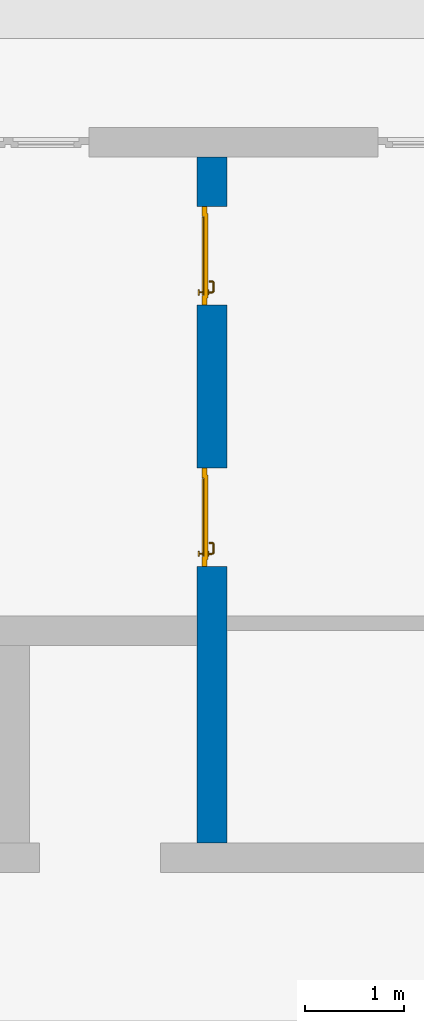
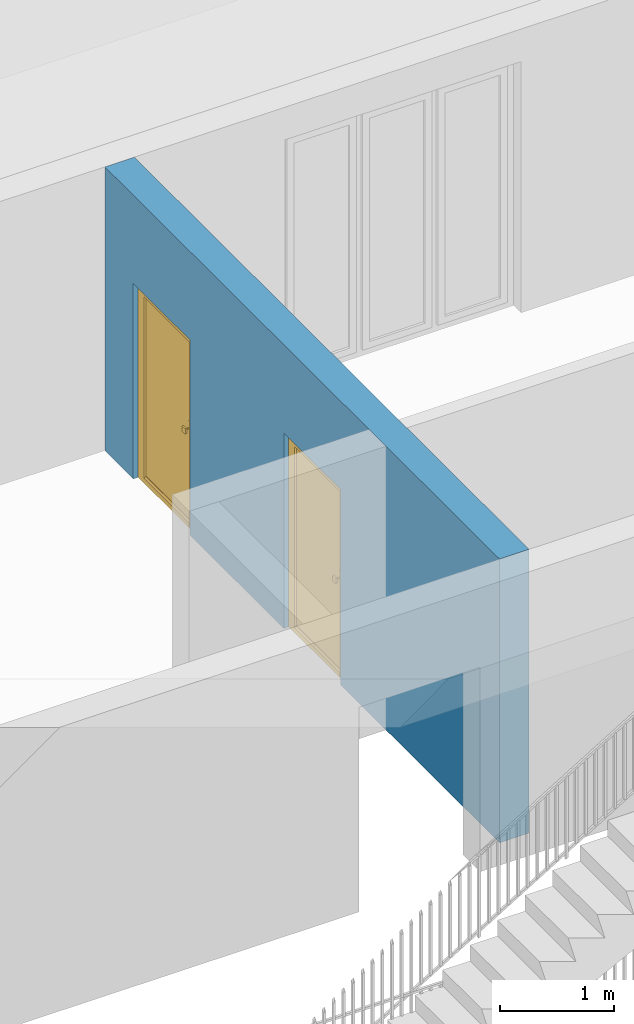
# One storey, part 11 of 23: 2 doors, 1 wall, 2 openings.
"""IFC4 building model written with IfcOpenShell, lengths in metres."""

from ifc_helpers import new_model, entity, si_unit, converted_unit, derived_unit, direction, frame, origin_with_axes, place, context, subcontext, project, spatial, polygons, source, transform, mapped, material, type_object, element, fill, save


model = new_model("IFC4")

# Units and contexts
model_context = context("Model", 3, precision=1e-05, world=origin_with_axes(), true_north=direction((0.0, 1.0)))
body_context = subcontext(model_context, "Body", "Model", "MODEL_VIEW")
ifc_project = project(units=[si_unit("LENGTHUNIT", "METRE"), si_unit("AREAUNIT", "SQUARE_METRE"), si_unit("VOLUMEUNIT", "CUBIC_METRE"), converted_unit("PLANEANGLEUNIT", "DEGREE", entity("IfcPlaneAngleMeasure", 0.0174532925199), si_unit("PLANEANGLEUNIT", "RADIAN"), dimensions=[0, 0, 0, 0, 0, 0, 0]), converted_unit("TIMEUNIT", "Year", entity("IfcTimeMeasure", 31556926.0), si_unit("TIMEUNIT", "SECOND"), dimensions=[0, 0, 1, 0, 0, 0, 0]), si_unit("MASSUNIT", "GRAM", prefix="KILO"), si_unit("THERMODYNAMICTEMPERATUREUNIT", "DEGREE_CELSIUS"), si_unit("LUMINOUSINTENSITYUNIT", "LUMEN"), si_unit("ENERGYUNIT", "JOULE", prefix="MEGA"), derived_unit("THERMALCONDUCTANCEUNIT", [(si_unit("POWERUNIT", "WATT"), 1), (si_unit("LENGTHUNIT", "METRE"), -1), (si_unit("THERMODYNAMICTEMPERATUREUNIT", "KELVIN"), -1)]), derived_unit("SPECIFICHEATCAPACITYUNIT", [(si_unit("ENERGYUNIT", "JOULE"), 1), (si_unit("MASSUNIT", "GRAM", prefix="KILO"), -1), (si_unit("THERMODYNAMICTEMPERATUREUNIT", "KELVIN"), -1)]), derived_unit("MASSDENSITYUNIT", [(si_unit("MASSUNIT", "GRAM", prefix="KILO"), 1), (si_unit("VOLUMEUNIT", "CUBIC_METRE"), -1)])], contexts=[model_context])

# Site, building, storey
site_placement = place(None, origin_with_axes())
site = spatial("IfcSite", under=ifc_project, at=site_placement, CompositionType="ELEMENT")
building_placement = place(site_placement, origin_with_axes())
building = spatial("IfcBuilding", under=site, at=building_placement, CompositionType="ELEMENT")
storey_placement = place(building_placement, origin_with_axes())
storey = spatial("IfcBuildingStorey", under=building, at=storey_placement, Name="0. Geschoss", CompositionType="ELEMENT", Elevation=0.0)

# Wall, openings, doors
ifc_material = material()
wall_type = type_object("IfcWallType", Name="300", PredefinedType="NOTDEFINED")
wall_placement = place(storey_placement, frame((-0.742199380397, 1.37118776896, 0.0), z_axis=(0.0, 0.0, 1.0), x_axis=(0.0, 1.0, 0.0)))
wall = element("IfcWall", 1, at=wall_placement, inside=storey, type_object=wall_type, material=ifc_material, Name="Wand-001", PredefinedType="NOTDEFINED", context=body_context, shape_type="Tessellation", body=[
    polygons([(3.1, -0.3, 0.0), (3.1, -0.3, 2.1), (4.1, -0.3, 2.1), (4.1, -0.3, 0.0), (5.75, -0.3, 0.0), (5.75, -0.3, 2.1), (6.75, -0.3, 2.1), (6.75, -0.3, 0.0), (7.25, -0.3, 0.0), (7.25, -0.3, 3.05), (0.3, -0.3, 3.05), (0.3, -0.3, 0.0), (3.1, -0.05, 0.0), (3.1, 0.0, 0.0), (3.1, 0.0, 2.1), (4.1, 0.0, 2.1), (4.1, -0.05, 0.0), (4.1, 0.0, 0.0), (5.75, 0.0, 0.0), (5.75, 0.0, 2.1), (6.75, 0.0, 2.1), (6.75, 0.0, 0.0), (7.25, 0.0, 0.0), (7.25, 0.0, 3.05), (0.3, 0.0, 3.05), (0.3, 0.0, 0.0)], [[[1, 2, 3, 4, 5, 6, 7, 8, 9, 10, 11, 12]], [[2, 1, 13, 14, 15]], [[3, 2, 15, 16]], [[17, 4, 3, 16, 18]], [[4, 17, 18, 19, 5]], [[19, 20, 6, 5]], [[20, 21, 7, 6]], [[21, 22, 8, 7]], [[23, 9, 8, 22]], [[23, 24, 10, 9]], [[25, 11, 10, 24]], [[12, 11, 25, 26]], [[13, 1, 12, 26, 14]], [[19, 18, 16, 15, 14, 26, 25, 24, 23, 22, 21, 20]]], closed=True),
])
opening_1_placement = place(wall_placement, frame((6.25, 0.0, 0.0), z_axis=(0.0, 0.0, 1.0), x_axis=(1.0, 0.0, 0.0)))
opening_1 = element("IfcOpeningElement", 2, at=opening_1_placement, cuts=wall, context=body_context, identifier="Reference", shape_type="Tessellation", body=[
    polygons([(-0.5, -0.05, 0.0), (-0.5, -0.05, 2.1), (-0.5, 0.001, 2.1), (-0.5, 0.001, 0.0), (-0.5, -0.301, 0.0), (-0.5, -0.301, 2.1), (0.5, -0.05, 2.1), (0.5, 0.001, 2.1), (0.5, -0.301, 2.1), (0.5, 0.001, 0.0), (0.5, -0.05, 0.0), (0.5, -0.301, 0.0)], [[[1, 2, 3, 4]], [[2, 1, 5, 6]], [[7, 8, 3, 2, 6, 9]], [[8, 10, 4, 3]], [[1, 4, 10, 11, 12, 5]], [[6, 5, 12, 9]], [[7, 11, 10, 8]], [[11, 7, 9, 12]]], closed=True),
])
opening_2_placement = place(wall_placement, frame((3.6, 0.0, 0.0), z_axis=(0.0, 0.0, 1.0), x_axis=(1.0, 0.0, 0.0)))
opening_2 = element("IfcOpeningElement", 3, at=opening_2_placement, cuts=wall, context=body_context, identifier="Reference", shape_type="Tessellation", body=[
    polygons([(-0.5, -0.05, 0.0), (-0.5, -0.05, 2.1), (-0.5, 0.001, 2.1), (-0.5, 0.001, 0.0), (-0.5, -0.301, 0.0), (-0.5, -0.301, 2.1), (0.5, -0.05, 2.1), (0.5, 0.001, 2.1), (0.5, -0.301, 2.1), (0.5, 0.001, 0.0), (0.5, -0.05, 0.0), (0.5, -0.301, 0.0)], [[[1, 2, 3, 4]], [[2, 1, 5, 6]], [[7, 8, 3, 2, 6, 9]], [[8, 10, 4, 3]], [[1, 4, 10, 11, 12, 5]], [[6, 5, 12, 9]], [[7, 11, 10, 8]], [[11, 7, 9, 12]]], closed=True),
])
door_type = type_object("IfcDoorType", Name="Eingang 01 1-Fl 26", OperationType="SINGLE_SWING_LEFT", PredefinedType="DOOR")
shared_shape = source(origin_with_axes(), body_context, "Body", "Tessellation", [
    polygons([(-0.5, -0.05, 0.0), (-0.5, -0.05, 2.1), (-0.5, -0.03, 2.1), (-0.5, -0.03, 0.0), (-0.4, -0.05, 0.0), (-0.4, -0.05, 2.0), (-0.1301, -0.05, 2.0), (-0.0001, -0.05, 2.0), (0.4, -0.05, 2.0), (0.4, -0.05, 0.0), (0.5, -0.05, 0.0), (0.5, -0.05, 2.1), (0.5, -0.03, 2.1), (0.5, -0.03, 0.0), (0.4, -0.03, 0.0), (0.4, -0.03, 2.0), (-0.0001, -0.03, 2.0), (-0.1301, -0.03, 2.0), (-0.4, -0.03, 2.0), (-0.4, -0.03, 0.0)], [[[1, 2, 3, 4]], [[1, 5, 6, 7, 8, 9, 10, 11, 12, 2]], [[2, 12, 13, 3]], [[4, 3, 13, 14, 15, 16, 17, 18, 19, 20]], [[5, 1, 4, 20]], [[6, 5, 20, 19]], [[7, 6, 19, 18]], [[8, 7, 18, 17]], [[9, 8, 17, 16]], [[10, 9, 16, 15]], [[11, 10, 15, 14]], [[12, 11, 14, 13]]], closed=True),
    polygons([(-0.5, -0.03, 0.0), (-0.5, -0.03, 2.1), (-0.5, 0.0, 2.1), (-0.5, 0.0, 0.0), (-0.43, -0.03, 0.0), (-0.43, -0.03, 2.03), (-0.1001, -0.03, 2.03), (-0.0301, -0.03, 2.03), (0.43, -0.03, 2.03), (0.43, -0.03, 0.0), (0.5, -0.03, 0.0), (0.5, -0.03, 2.1), (0.5, 0.0, 2.1), (0.5, 0.0, 0.0), (0.43, 0.0, 0.0), (0.43, 0.0, 2.03), (-0.0301, 0.0, 2.03), (-0.1001, 0.0, 2.03), (-0.43, 0.0, 2.03), (-0.43, 0.0, 0.0)], [[[1, 2, 3, 4]], [[1, 5, 6, 7, 8, 9, 10, 11, 12, 2]], [[2, 12, 13, 3]], [[4, 3, 13, 14, 15, 16, 17, 18, 19, 20]], [[5, 1, 4, 20]], [[6, 5, 20, 19]], [[7, 6, 19, 18]], [[8, 7, 18, 17]], [[9, 8, 17, 16]], [[10, 9, 16, 15]], [[11, 10, 15, 14]], [[12, 11, 14, 13]]], closed=True),
    polygons([(-0.43, 0.01, 0.0), (-0.43, 0.01, 2.03), (0.43, 0.01, 2.03), (0.43, 0.01, 0.0), (-0.43, -0.03, 0.0), (-0.43, -0.03, 2.03), (0.43, -0.03, 2.03), (0.43, -0.03, 0.0)], [[[1, 2, 3, 4]], [[1, 5, 6, 2]], [[2, 6, 7, 3]], [[3, 7, 8, 4]], [[4, 8, 5, 1]], [[8, 7, 6, 5]]], closed=True),
    polygons([(-0.395, -0.05, 0.0), (0.395, -0.05, 0.0), (0.395, -0.05, 0.05), (-0.395, -0.05, 0.05), (-0.395, -0.03, 0.0), (0.395, -0.03, 0.0), (0.395, -0.03, 0.07), (0.395, -0.035, 0.07), (-0.395, -0.035, 0.07), (-0.395, -0.03, 0.07)], [[[1, 2, 3, 4]], [[5, 6, 2, 1]], [[2, 6, 7, 8, 3]], [[4, 3, 8, 9]], [[1, 4, 9, 10, 5]], [[10, 7, 6, 5]], [[9, 8, 7, 10]]], closed=True),
    polygons([(0.3835, 0.02, 1.0733826859), (0.37, 0.02, 1.077), (0.37, 0.0199, 1.077), (0.3835, 0.0199, 1.0733826859), (0.393382685902, 0.02, 1.0635), (0.397, 0.02, 1.05), (0.393382685902, 0.02, 1.0365), (0.3835, 0.02, 1.0266173141), (0.37, 0.02, 1.023), (0.3565, 0.02, 1.0266173141), (0.346617314098, 0.02, 1.0365), (0.343, 0.02, 1.05), (0.346617314098, 0.02, 1.0635), (0.3565, 0.02, 1.0733826859), (0.3565, 0.0199, 1.0733826859), (0.37, 0.0101, 1.077), (0.3835, 0.0101, 1.0733826859), (0.393382685902, 0.0199, 1.0635), (0.397, 0.0199, 1.05), (0.393382685902, 0.0199, 1.0365), (0.3835, 0.0199, 1.0266173141), (0.37, 0.0199, 1.023), (0.3565, 0.0199, 1.0266173141), (0.346617314098, 0.0199, 1.0365), (0.343, 0.0199, 1.05), (0.346617314098, 0.0199, 1.0635), (0.3565, 0.0101, 1.0733826859), (0.37, 0.01, 1.077), (0.3835, 0.01, 1.0733826859), (0.393382685902, 0.0101, 1.0635), (0.397, 0.0101, 1.05), (0.393382685902, 0.0101, 1.0365), (0.3835, 0.0101, 1.0266173141), (0.37, 0.0101, 1.023), (0.3565, 0.0101, 1.0266173141), (0.346617314098, 0.0101, 1.0365), (0.343, 0.0101, 1.05), (0.346617314098, 0.0101, 1.0635), (0.3565, 0.01, 1.0733826859), (0.346617314098, 0.01, 1.0635), (0.343, 0.01, 1.05), (0.346617314098, 0.01, 1.0365), (0.3565, 0.01, 1.0266173141), (0.37, 0.01, 1.023), (0.3835, 0.01, 1.0266173141), (0.393382685902, 0.01, 1.0365), (0.397, 0.01, 1.05), (0.393382685902, 0.01, 1.0635)], [[[1, 2, 3, 4]], [[2, 1, 5, 6, 7, 8, 9, 10, 11, 12, 13, 14]], [[2, 14, 15, 3]], [[4, 3, 16, 17]], [[5, 1, 4, 18]], [[6, 5, 18, 19]], [[7, 6, 19, 20]], [[8, 7, 20, 21]], [[9, 8, 21, 22]], [[10, 9, 22, 23]], [[11, 10, 23, 24]], [[12, 11, 24, 25]], [[13, 12, 25, 26]], [[14, 13, 26, 15]], [[3, 15, 27, 16]], [[17, 16, 28, 29]], [[18, 4, 17, 30]], [[19, 18, 30, 31]], [[20, 19, 31, 32]], [[21, 20, 32, 33]], [[22, 21, 33, 34]], [[23, 22, 34, 35]], [[24, 23, 35, 36]], [[25, 24, 36, 37]], [[26, 25, 37, 38]], [[15, 26, 38, 27]], [[16, 27, 39, 28]], [[28, 39, 40, 41, 42, 43, 44, 45, 46, 47, 48, 29]], [[30, 17, 29, 48]], [[31, 30, 48, 47]], [[32, 31, 47, 46]], [[33, 32, 46, 45]], [[34, 33, 45, 44]], [[35, 34, 44, 43]], [[36, 35, 43, 42]], [[37, 36, 42, 41]], [[38, 37, 41, 40]], [[27, 38, 40, 39]]], closed=True),
    polygons([(0.362532169224, 0.019, 0.959692280177), (0.363279754556, 0.019, 0.961639806549), (0.35705, 0.019, 0.972430057958), (0.347569942042, 0.019, 0.96295), (0.365, 0.019, 0.952886751346), (0.365, 0.019, 0.9544), (0.362532169224, 0.02, 0.959692280177), (0.363279754556, 0.02, 0.961639806549), (0.364624817685, 0.02, 0.965143815798), (0.364624817685, 0.019, 0.965143815798), (0.37, 0.019, 0.967425445323), (0.37, 0.019, 0.9759), (0.357, 0.019, 0.972516660498), (0.347483339502, 0.019, 0.963), (0.365, 0.019, 0.95), (0.3441, 0.019, 0.95), (0.365, 0.019, 0.947113248654), (0.365, 0.019, 0.941339745962), (0.365, 0.019, 0.9375), (0.365, 0.02, 0.9375), (0.365, 0.02, 0.941339745962), (0.365, 0.02, 0.947113248654), (0.365, 0.02, 0.95), (0.365, 0.02, 0.952886751346), (0.365, 0.02, 0.9544), (0.346703916638, 0.02, 0.96345), (0.35655, 0.02, 0.973296083362), (0.37, 0.02, 0.9769), (0.37, 0.02, 0.967425445323), (0.375375182315, 0.019, 0.965143815798), (0.376720245444, 0.019, 0.961639806549), (0.38295, 0.019, 0.972430057958), (0.37, 0.019, 0.976), (0.357, 0.0189, 0.972516660498), (0.347483339502, 0.0189, 0.963), (0.344, 0.019, 0.95), (0.347569942042, 0.019, 0.93705), (0.35705, 0.019, 0.927569942042), (0.37, 0.019, 0.9241), (0.37, 0.019, 0.9325), (0.366464466094, 0.019, 0.933964466094), (0.366464466094, 0.02, 0.933964466094), (0.37, 0.02, 0.9231), (0.35655, 0.02, 0.926703916638), (0.37, 0.02, 0.9325), (0.346703916638, 0.02, 0.93655), (0.3431, 0.02, 0.95), (0.346617314098, 0.02, 0.9635), (0.3565, 0.02, 0.973382685902), (0.37, 0.02, 0.977), (0.375375182315, 0.02, 0.965143815798), (0.38345, 0.02, 0.973296083362), (0.376720245444, 0.02, 0.961639806549), (0.377467830776, 0.02, 0.959692280177), (0.377467830776, 0.019, 0.959692280177), (0.375, 0.019, 0.9544), (0.375, 0.019, 0.952886751346), (0.392430057958, 0.019, 0.96295), (0.383, 0.019, 0.972516660498), (0.37, 0.0189, 0.976), (0.357, 0.0101, 0.972516660498), (0.347483339502, 0.0101, 0.963), (0.344, 0.0189, 0.95), (0.347483339502, 0.019, 0.937), (0.357, 0.019, 0.927483339502), (0.37, 0.019, 0.924), (0.38295, 0.019, 0.927569942042), (0.375, 0.019, 0.941339745962), (0.375, 0.019, 0.9375), (0.373535533906, 0.019, 0.933964466094), (0.37, 0.02, 0.923), (0.3565, 0.02, 0.926617314098), (0.38345, 0.02, 0.926703916638), (0.373535533906, 0.02, 0.933964466094), (0.375, 0.02, 0.9375), (0.375, 0.02, 0.941339745962), (0.346617314098, 0.02, 0.9365), (0.343, 0.02, 0.95), (0.346617314098, 0.0199, 0.9635), (0.3565, 0.0199, 0.973382685902), (0.37, 0.0199, 0.977), (0.3835, 0.02, 0.973382685902), (0.393296083362, 0.02, 0.96345), (0.375, 0.02, 0.952886751346), (0.375, 0.02, 0.9544), (0.375, 0.02, 0.95), (0.375, 0.02, 0.947113248654), (0.375, 0.019, 0.947113248654), (0.375, 0.019, 0.95), (0.3959, 0.019, 0.95), (0.392516660498, 0.019, 0.963), (0.383, 0.0189, 0.972516660498), (0.37, 0.0101, 0.976), (0.357, 0.01, 0.972516660498), (0.347483339502, 0.01, 0.963), (0.344, 0.0101, 0.95), (0.347483339502, 0.0189, 0.937), (0.357, 0.0189, 0.927483339502), (0.37, 0.0189, 0.924), (0.383, 0.019, 0.927483339502), (0.392430057958, 0.019, 0.93705), (0.37, 0.0199, 0.923), (0.3565, 0.0199, 0.926617314098), (0.3835, 0.02, 0.926617314098), (0.393296083362, 0.02, 0.93655), (0.346617314098, 0.0199, 0.9365), (0.343, 0.0199, 0.95), (0.346617314098, 0.0101, 0.9635), (0.3565, 0.0101, 0.973382685902), (0.37, 0.0101, 0.977), (0.3835, 0.0199, 0.973382685902), (0.393382685902, 0.02, 0.9635), (0.3969, 0.02, 0.95), (0.396, 0.019, 0.95), (0.392516660498, 0.0189, 0.963), (0.383, 0.0101, 0.972516660498), (0.37, 0.01, 0.976), (0.35695, 0.01, 0.972603263039), (0.347396736961, 0.01, 0.96305), (0.344, 0.01, 0.95), (0.347483339502, 0.0101, 0.937), (0.357, 0.0101, 0.927483339502), (0.37, 0.0101, 0.924), (0.383, 0.0189, 0.927483339502), (0.392516660498, 0.019, 0.937), (0.37, 0.0101, 0.923), (0.3565, 0.0101, 0.926617314098), (0.3835, 0.0199, 0.926617314098), (0.393382685902, 0.02, 0.9365), (0.346617314098, 0.0101, 0.9365), (0.343, 0.0101, 0.95), (0.346617314098, 0.01, 0.9635), (0.3565, 0.01, 0.973382685902), (0.37, 0.01, 0.977), (0.3835, 0.0101, 0.973382685902), (0.393382685902, 0.0199, 0.9635), (0.397, 0.02, 0.95), (0.396, 0.0189, 0.95), (0.392516660498, 0.0101, 0.963), (0.383, 0.01, 0.972516660498), (0.37, 0.01, 0.9761), (0.35655, 0.01, 0.973296083362), (0.346703916638, 0.01, 0.96345), (0.3439, 0.01, 0.95), (0.347483339502, 0.01, 0.937), (0.357, 0.01, 0.927483339502), (0.37, 0.01, 0.924), (0.383, 0.0101, 0.927483339502), (0.392516660498, 0.0189, 0.937), (0.37, 0.01, 0.923), (0.3565, 0.01, 0.926617314098), (0.3835, 0.0101, 0.926617314098), (0.393382685902, 0.0199, 0.9365), (0.346617314098, 0.01, 0.9365), (0.343, 0.01, 0.95), (0.37, 0.01, 0.9769), (0.3835, 0.01, 0.973382685902), (0.393382685902, 0.0101, 0.9635), (0.397, 0.0199, 0.95), (0.396, 0.0101, 0.95), (0.392516660498, 0.01, 0.963), (0.38305, 0.01, 0.972603263039), (0.3431, 0.01, 0.95), (0.347396736961, 0.01, 0.93695), (0.35695, 0.01, 0.927396736961), (0.37, 0.01, 0.9239), (0.383, 0.01, 0.927483339502), (0.392516660498, 0.0101, 0.937), (0.37, 0.01, 0.9231), (0.35655, 0.01, 0.926703916638), (0.3835, 0.01, 0.926617314098), (0.393382685902, 0.0101, 0.9365), (0.346703916638, 0.01, 0.93655), (0.38345, 0.01, 0.973296083362), (0.393382685902, 0.01, 0.9635), (0.397, 0.0101, 0.95), (0.396, 0.01, 0.95), (0.392603263039, 0.01, 0.96305), (0.38305, 0.01, 0.927396736961), (0.392516660498, 0.01, 0.937), (0.38345, 0.01, 0.926703916638), (0.393382685902, 0.01, 0.9365), (0.393296083362, 0.01, 0.96345), (0.397, 0.01, 0.95), (0.3961, 0.01, 0.95), (0.392603263039, 0.01, 0.93695), (0.393296083362, 0.01, 0.93655), (0.3969, 0.01, 0.95)], [[[1, 2, 3, 4, 5, 6]], [[1, 7, 8, 9, 10, 2]], [[10, 11, 12, 3, 2]], [[4, 3, 13, 14]], [[15, 5, 4, 16]], [[6, 5, 15, 17, 18, 19, 20, 21, 22, 23, 24, 25]], [[6, 25, 7, 1]], [[7, 25, 24, 26, 27, 8]], [[9, 8, 27, 28, 29]], [[10, 9, 29, 11]], [[30, 31, 32, 12, 11]], [[3, 12, 33, 13]], [[14, 13, 34, 35]], [[16, 4, 14, 36]], [[17, 15, 16, 37]], [[18, 17, 37, 38]], [[38, 39, 40, 41, 19, 18]], [[19, 41, 42, 20]], [[43, 44, 21, 20, 42, 45]], [[22, 21, 44, 46]], [[23, 22, 46, 47]], [[24, 23, 47, 26]], [[48, 49, 27, 26]], [[49, 50, 28, 27]], [[51, 29, 28, 52, 53]], [[11, 29, 51, 30]], [[30, 51, 53, 54, 55, 31]], [[55, 56, 57, 58, 32, 31]], [[12, 32, 59, 33]], [[13, 33, 60, 34]], [[35, 34, 61, 62]], [[36, 14, 35, 63]], [[37, 16, 36, 64]], [[38, 37, 64, 65]], [[39, 38, 65, 66]], [[39, 67, 68, 69, 70, 40]], [[41, 40, 45, 42]], [[71, 72, 44, 43]], [[73, 43, 45, 74, 75, 76]], [[72, 77, 46, 44]], [[77, 78, 47, 46]], [[78, 48, 26, 47]], [[79, 80, 49, 48]], [[80, 81, 50, 49]], [[50, 82, 52, 28]], [[54, 53, 52, 83, 84, 85]], [[55, 54, 85, 56]], [[85, 84, 86, 87, 76, 75, 69, 68, 88, 89, 57, 56]], [[57, 89, 90, 58]], [[32, 58, 91, 59]], [[33, 59, 92, 60]], [[34, 60, 93, 61]], [[62, 61, 94, 95]], [[63, 35, 62, 96]], [[64, 36, 63, 97]], [[65, 64, 97, 98]], [[66, 65, 98, 99]], [[67, 39, 66, 100]], [[88, 68, 67, 101]], [[70, 69, 75, 74]], [[40, 70, 74, 45]], [[102, 103, 72, 71]], [[104, 71, 43, 73]], [[76, 87, 105, 73]], [[103, 106, 77, 72]], [[106, 107, 78, 77]], [[107, 79, 48, 78]], [[108, 109, 80, 79]], [[109, 110, 81, 80]], [[81, 111, 82, 50]], [[82, 112, 83, 52]], [[86, 84, 83, 113]], [[87, 86, 113, 105]], [[89, 88, 101, 90]], [[58, 90, 114, 91]], [[59, 91, 115, 92]], [[60, 92, 116, 93]], [[61, 93, 117, 94]], [[95, 94, 118, 119]], [[96, 62, 95, 120]], [[97, 63, 96, 121]], [[98, 97, 121, 122]], [[99, 98, 122, 123]], [[100, 66, 99, 124]], [[101, 67, 100, 125]], [[126, 127, 103, 102]], [[128, 102, 71, 104]], [[129, 104, 73, 105]], [[127, 130, 106, 103]], [[130, 131, 107, 106]], [[131, 108, 79, 107]], [[132, 133, 109, 108]], [[133, 134, 110, 109]], [[110, 135, 111, 81]], [[111, 136, 112, 82]], [[112, 137, 113, 83]], [[137, 129, 105, 113]], [[90, 101, 125, 114]], [[91, 114, 138, 115]], [[92, 115, 139, 116]], [[93, 116, 140, 117]], [[94, 117, 141, 118]], [[119, 118, 142, 143]], [[120, 95, 119, 144]], [[121, 96, 120, 145]], [[122, 121, 145, 146]], [[123, 122, 146, 147]], [[124, 99, 123, 148]], [[125, 100, 124, 149]], [[150, 151, 127, 126]], [[152, 126, 102, 128]], [[153, 128, 104, 129]], [[151, 154, 130, 127]], [[154, 155, 131, 130]], [[155, 132, 108, 131]], [[143, 142, 133, 132]], [[142, 156, 134, 133]], [[134, 157, 135, 110]], [[135, 158, 136, 111]], [[136, 159, 137, 112]], [[159, 153, 129, 137]], [[114, 125, 149, 138]], [[115, 138, 160, 139]], [[116, 139, 161, 140]], [[117, 140, 162, 141]], [[118, 141, 156, 142]], [[144, 119, 143, 163]], [[145, 120, 144, 164]], [[146, 145, 164, 165]], [[147, 146, 165, 166]], [[148, 123, 147, 167]], [[149, 124, 148, 168]], [[169, 170, 151, 150]], [[171, 150, 126, 152]], [[172, 152, 128, 153]], [[170, 173, 154, 151]], [[173, 163, 155, 154]], [[163, 143, 132, 155]], [[156, 174, 157, 134]], [[157, 175, 158, 135]], [[158, 176, 159, 136]], [[176, 172, 153, 159]], [[138, 149, 168, 160]], [[139, 160, 177, 161]], [[140, 161, 178, 162]], [[141, 162, 174, 156]], [[164, 144, 163, 173]], [[165, 164, 173, 170]], [[166, 165, 170, 169]], [[167, 147, 166, 179]], [[168, 148, 167, 180]], [[181, 169, 150, 171]], [[182, 171, 152, 172]], [[174, 183, 175, 157]], [[175, 184, 176, 158]], [[184, 182, 172, 176]], [[160, 168, 180, 177]], [[161, 177, 185, 178]], [[162, 178, 183, 174]], [[179, 166, 169, 181]], [[180, 167, 179, 186]], [[187, 181, 171, 182]], [[183, 188, 184, 175]], [[188, 187, 182, 184]], [[177, 180, 186, 185]], [[178, 185, 188, 183]], [[186, 179, 181, 187]], [[185, 186, 187, 188]]], closed=True),
    polygons([(0.38, 0.02, 1.05), (0.377071067812, 0.02, 1.04292893219), (0.377071067812, 0.050696439392, 1.04292893219), (0.38, 0.0509849140336, 1.05), (0.37, 0.02, 1.04), (0.37, 0.05, 1.04), (0.375518993221, 0.0584992452783, 1.04292893219), (0.378277987014, 0.0596420579258, 1.05), (0.377071067812, 0.02, 1.05707106781), (0.377071067812, 0.050696439392, 1.05707106781), (0.362928932188, 0.02, 1.04292893219), (0.362928932188, 0.049303560608, 1.04292893219), (0.368858192988, 0.0557402514855, 1.04), (0.370704557509, 0.0657045575088, 1.04292893219), (0.372816199938, 0.0678161999379, 1.05), (0.375518993221, 0.0584992452783, 1.05707106781), (0.37, 0.02, 1.06), (0.37, 0.05, 1.06), (0.36, 0.02, 1.05), (0.36, 0.0490150859664, 1.05), (0.362197392755, 0.0529812576926, 1.04292893219), (0.365606601718, 0.0606066017178, 1.04), (0.363499245278, 0.0705189932208, 1.04292893219), (0.364642057926, 0.0732779870137, 1.05), (0.370704557509, 0.0657045575088, 1.05707106781), (0.368858192988, 0.0557402514855, 1.06), (0.362928932188, 0.02, 1.05707106781), (0.362928932188, 0.049303560608, 1.05707106781), (0.359438398962, 0.0518384450452, 1.05), (0.360508645927, 0.0555086459268, 1.04292893219), (0.360740251485, 0.0638581929877, 1.04), (0.355696439392, 0.0720710678119, 1.04292893219), (0.355984914034, 0.075, 1.05), (0.363499245278, 0.0705189932208, 1.05707106781), (0.365606601718, 0.0606066017178, 1.06), (0.362197392755, 0.0529812576926, 1.05707106781), (0.358397003498, 0.0533970034977, 1.05), (0.357981257693, 0.0571973927545, 1.04292893219), (0.355, 0.065, 1.04), (0.274303560608, 0.0720710678119, 1.04292893219), (0.274015085966, 0.075, 1.05), (0.355696439392, 0.0720710678119, 1.05707106781), (0.360740251485, 0.0638581929877, 1.06), (0.360508645927, 0.0555086459268, 1.05707106781), (0.356838445045, 0.0544383989617, 1.05), (0.354303560608, 0.0579289321881, 1.04292893219), (0.275, 0.065, 1.04), (0.266500754722, 0.0705189932208, 1.04292893219), (0.265357942074, 0.0732779870137, 1.05), (0.274303560608, 0.0720710678119, 1.05707106781), (0.355, 0.065, 1.06), (0.357981257693, 0.0571973927545, 1.05707106781), (0.354015085966, 0.055, 1.05), (0.275696439392, 0.0579289321881, 1.04292893219), (0.269259748515, 0.0638581929877, 1.04), (0.259295442491, 0.0657045575088, 1.04292893219), (0.257183800062, 0.0678161999379, 1.05), (0.266500754722, 0.0705189932208, 1.05707106781), (0.275, 0.065, 1.06), (0.354303560608, 0.0579289321881, 1.05707106781), (0.275984914034, 0.055, 1.05), (0.272018742307, 0.0571973927545, 1.04292893219), (0.264393398282, 0.0606066017178, 1.04), (0.254481006779, 0.0584992452783, 1.04292893219), (0.251722012986, 0.0596420579258, 1.05), (0.259295442491, 0.0657045575088, 1.05707106781), (0.269259748515, 0.0638581929877, 1.06), (0.275696439392, 0.0579289321881, 1.05707106781), (0.273161554955, 0.0544383989617, 1.05), (0.269491354073, 0.0555086459268, 1.04292893219), (0.261141807012, 0.0557402514855, 1.04), (0.252928932188, 0.050696439392, 1.04292893219), (0.25, 0.0509849140336, 1.05), (0.254481006779, 0.0584992452783, 1.05707106781), (0.264393398282, 0.0606066017178, 1.06), (0.272018742307, 0.0571973927545, 1.05707106781), (0.271602996502, 0.0533970034977, 1.05), (0.267802607245, 0.0529812576926, 1.04292893219), (0.26, 0.05, 1.04), (0.252928932188, 0.02, 1.04292893219), (0.25, 0.02, 1.05), (0.252928932188, 0.050696439392, 1.05707106781), (0.261141807012, 0.0557402514855, 1.06), (0.269491354073, 0.0555086459268, 1.05707106781), (0.270561601038, 0.0518384450452, 1.05), (0.267071067812, 0.049303560608, 1.04292893219), (0.26, 0.02, 1.04), (0.267071067812, 0.02, 1.04292893219), (0.27, 0.02, 1.05), (0.267071067812, 0.02, 1.05707106781), (0.26, 0.02, 1.06), (0.252928932188, 0.02, 1.05707106781), (0.26, 0.05, 1.06), (0.267802607245, 0.0529812576926, 1.05707106781), (0.27, 0.0490150859664, 1.05), (0.267071067812, 0.049303560608, 1.05707106781)], [[[1, 2, 3, 4]], [[2, 5, 6, 3]], [[4, 3, 7, 8]], [[9, 1, 4, 10]], [[5, 11, 12, 6]], [[3, 6, 13, 7]], [[8, 7, 14, 15]], [[10, 4, 8, 16]], [[17, 9, 10, 18]], [[11, 19, 20, 12]], [[6, 12, 21, 13]], [[7, 13, 22, 14]], [[15, 14, 23, 24]], [[16, 8, 15, 25]], [[18, 10, 16, 26]], [[27, 17, 18, 28]], [[19, 27, 28, 20]], [[12, 20, 29, 21]], [[13, 21, 30, 22]], [[14, 22, 31, 23]], [[24, 23, 32, 33]], [[25, 15, 24, 34]], [[26, 16, 25, 35]], [[28, 18, 26, 36]], [[20, 28, 36, 29]], [[21, 29, 37, 30]], [[22, 30, 38, 31]], [[23, 31, 39, 32]], [[33, 32, 40, 41]], [[34, 24, 33, 42]], [[35, 25, 34, 43]], [[36, 26, 35, 44]], [[29, 36, 44, 37]], [[30, 37, 45, 38]], [[31, 38, 46, 39]], [[32, 39, 47, 40]], [[41, 40, 48, 49]], [[42, 33, 41, 50]], [[43, 34, 42, 51]], [[44, 35, 43, 52]], [[37, 44, 52, 45]], [[38, 45, 53, 46]], [[39, 46, 54, 47]], [[40, 47, 55, 48]], [[49, 48, 56, 57]], [[50, 41, 49, 58]], [[51, 42, 50, 59]], [[52, 43, 51, 60]], [[45, 52, 60, 53]], [[46, 53, 61, 54]], [[47, 54, 62, 55]], [[48, 55, 63, 56]], [[57, 56, 64, 65]], [[58, 49, 57, 66]], [[59, 50, 58, 67]], [[60, 51, 59, 68]], [[53, 60, 68, 61]], [[54, 61, 69, 62]], [[55, 62, 70, 63]], [[56, 63, 71, 64]], [[65, 64, 72, 73]], [[66, 57, 65, 74]], [[67, 58, 66, 75]], [[68, 59, 67, 76]], [[61, 68, 76, 69]], [[62, 69, 77, 70]], [[63, 70, 78, 71]], [[64, 71, 79, 72]], [[73, 72, 80, 81]], [[74, 65, 73, 82]], [[75, 66, 74, 83]], [[76, 67, 75, 84]], [[69, 76, 84, 77]], [[70, 77, 85, 78]], [[71, 78, 86, 79]], [[72, 79, 87, 80]], [[81, 80, 87, 88, 89, 90, 91, 92]], [[82, 73, 81, 92]], [[83, 74, 82, 93]], [[84, 75, 83, 94]], [[77, 84, 94, 85]], [[78, 85, 95, 86]], [[79, 86, 88, 87]], [[86, 95, 89, 88]], [[95, 96, 90, 89]], [[96, 93, 91, 90]], [[93, 82, 92, 91]], [[94, 83, 93, 96]], [[85, 94, 96, 95]]], closed=False),
    polygons([(0.364696699141, -0.035, 1.04469669914), (0.3625, -0.035, 1.05), (0.364696699141, -0.035, 1.05530330086), (0.37, -0.035, 1.0575), (0.375303300859, -0.035, 1.05530330086), (0.3775, -0.035, 1.05), (0.375303300859, -0.035, 1.04469669914), (0.37, -0.035, 1.0425), (0.364696699141, -0.075, 1.04469669914), (0.3625, -0.075, 1.05), (0.364696699141, -0.075, 1.05530330086), (0.37, -0.075, 1.0575), (0.375303300859, -0.075, 1.05530330086), (0.3775, -0.075, 1.05), (0.375303300859, -0.075, 1.04469669914), (0.37, -0.075, 1.0425)], [[[1, 2, 3, 4, 5, 6, 7, 8]], [[1, 9, 10, 2]], [[2, 10, 11, 3]], [[3, 11, 12, 4]], [[4, 12, 13, 5]], [[5, 13, 14, 6]], [[6, 14, 15, 7]], [[7, 15, 16, 8]], [[8, 16, 9, 1]], [[9, 16, 15, 14, 13, 12, 11, 10]]], closed=True),
    polygons([(0.395, -0.03, 0.975), (0.395, -0.035, 0.975), (0.393096988313, -0.035, 0.965432914191), (0.393096988313, -0.03, 0.965432914191), (0.395, -0.03, 1.1), (0.395, -0.035, 1.1), (0.393096988313, -0.035, 1.10956708581), (0.38767766953, -0.035, 1.11767766953), (0.379567085809, -0.035, 1.12309698831), (0.37, -0.035, 1.125), (0.360432914191, -0.035, 1.12309698831), (0.35232233047, -0.035, 1.11767766953), (0.346903011687, -0.035, 1.10956708581), (0.345, -0.035, 1.1), (0.345, -0.035, 0.975), (0.346903011687, -0.035, 0.965432914191), (0.35232233047, -0.035, 0.95732233047), (0.360432914191, -0.035, 0.951903011687), (0.37, -0.035, 0.95), (0.379567085809, -0.035, 0.951903011687), (0.38767766953, -0.035, 0.95732233047), (0.38767766953, -0.03, 0.95732233047), (0.379567085809, -0.03, 0.951903011687), (0.37, -0.03, 0.95), (0.360432914191, -0.03, 0.951903011687), (0.35232233047, -0.03, 0.95732233047), (0.346903011687, -0.03, 0.965432914191), (0.345, -0.03, 0.975), (0.345, -0.03, 1.1), (0.346903011687, -0.03, 1.10956708581), (0.35232233047, -0.03, 1.11767766953), (0.360432914191, -0.03, 1.12309698831), (0.37, -0.03, 1.125), (0.379567085809, -0.03, 1.12309698831), (0.38767766953, -0.03, 1.11767766953), (0.393096988313, -0.03, 1.10956708581)], [[[1, 2, 3, 4]], [[5, 6, 2, 1]], [[2, 6, 7, 8, 9, 10, 11, 12, 13, 14, 15, 16, 17, 18, 19, 20, 21, 3]], [[4, 3, 21, 22]], [[1, 4, 22, 23, 24, 25, 26, 27, 28, 29, 30, 31, 32, 33, 34, 35, 36, 5]], [[36, 7, 6, 5]], [[35, 8, 7, 36]], [[34, 9, 8, 35]], [[33, 10, 9, 34]], [[32, 11, 10, 33]], [[31, 12, 11, 32]], [[30, 13, 12, 31]], [[29, 14, 13, 30]], [[28, 15, 14, 29]], [[27, 16, 15, 28]], [[26, 17, 16, 27]], [[25, 18, 17, 26]], [[24, 19, 18, 25]], [[23, 20, 19, 24]], [[22, 21, 20, 23]]], closed=True),
    polygons([(0.39, -0.075, 1.08), (0.39, -0.09, 1.08), (0.395, -0.09, 1.07866025404), (0.395, -0.075, 1.07866025404), (0.35, -0.075, 1.08), (0.35, -0.09, 1.08), (0.345, -0.09, 1.07866025404), (0.341339745962, -0.09, 1.075), (0.34, -0.09, 1.07), (0.34, -0.09, 1.03), (0.341339745962, -0.09, 1.025), (0.345, -0.09, 1.02133974596), (0.35, -0.09, 1.02), (0.39, -0.09, 1.02), (0.395, -0.09, 1.02133974596), (0.398660254038, -0.09, 1.025), (0.4, -0.09, 1.03), (0.4, -0.09, 1.07), (0.398660254038, -0.09, 1.075), (0.398660254038, -0.075, 1.075), (0.4, -0.075, 1.07), (0.4, -0.075, 1.03), (0.398660254038, -0.075, 1.025), (0.395, -0.075, 1.02133974596), (0.39, -0.075, 1.02), (0.35, -0.075, 1.02), (0.345, -0.075, 1.02133974596), (0.341339745962, -0.075, 1.025), (0.34, -0.075, 1.03), (0.34, -0.075, 1.07), (0.341339745962, -0.075, 1.075), (0.345, -0.075, 1.07866025404)], [[[1, 2, 3, 4]], [[5, 6, 2, 1]], [[2, 6, 7, 8, 9, 10, 11, 12, 13, 14, 15, 16, 17, 18, 19, 3]], [[4, 3, 19, 20]], [[1, 4, 20, 21, 22, 23, 24, 25, 26, 27, 28, 29, 30, 31, 32, 5]], [[32, 7, 6, 5]], [[31, 8, 7, 32]], [[30, 9, 8, 31]], [[29, 10, 9, 30]], [[28, 11, 10, 29]], [[27, 12, 11, 28]], [[26, 13, 12, 27]], [[25, 14, 13, 26]], [[24, 15, 14, 25]], [[23, 16, 15, 24]], [[22, 17, 16, 23]], [[21, 18, 17, 22]], [[20, 19, 18, 21]]], closed=True),
])
door_1_placement = place(opening_1_placement, frame((0.4, 0.0, 0.0), z_axis=(0.0, 0.0, 1.0), x_axis=(-1.0, 0.0, 0.0)))
door_1 = element("IfcDoor", 4, at=door_1_placement, inside=storey, type_object=door_type, OverallHeight=2.1, OverallWidth=1.0, PredefinedType="DOOR", context=body_context, shape_type="MappedRepresentation", body=[
    mapped(shared_shape, transform((0.4, 0.1, 0.0))),
])
fill(opening_1, door_1)
door_2_placement = place(opening_2_placement, frame((0.4, 0.0, 0.0), z_axis=(0.0, 0.0, 1.0), x_axis=(-1.0, 0.0, 0.0)))
door_2 = element("IfcDoor", 5, at=door_2_placement, inside=storey, type_object=door_type, OverallHeight=2.1, OverallWidth=1.0, PredefinedType="DOOR", context=body_context, shape_type="MappedRepresentation", body=[
    mapped(shared_shape, transform((0.4, 0.1, 0.0))),
])
fill(opening_2, door_2)

save(model, "model.ifc")
